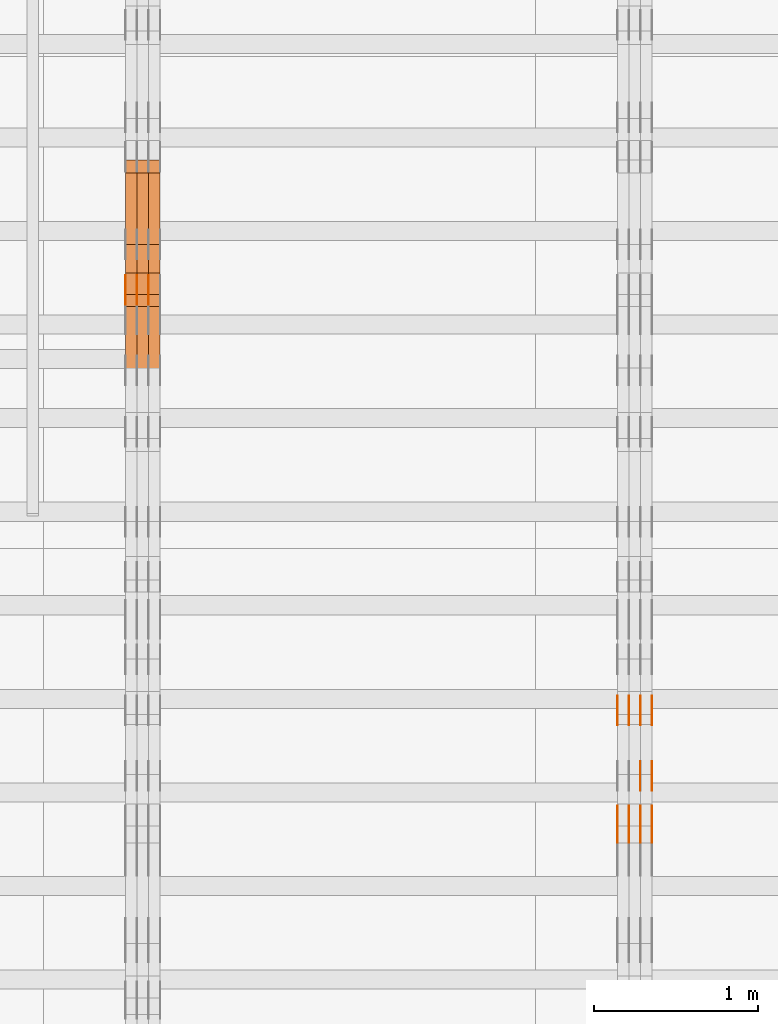
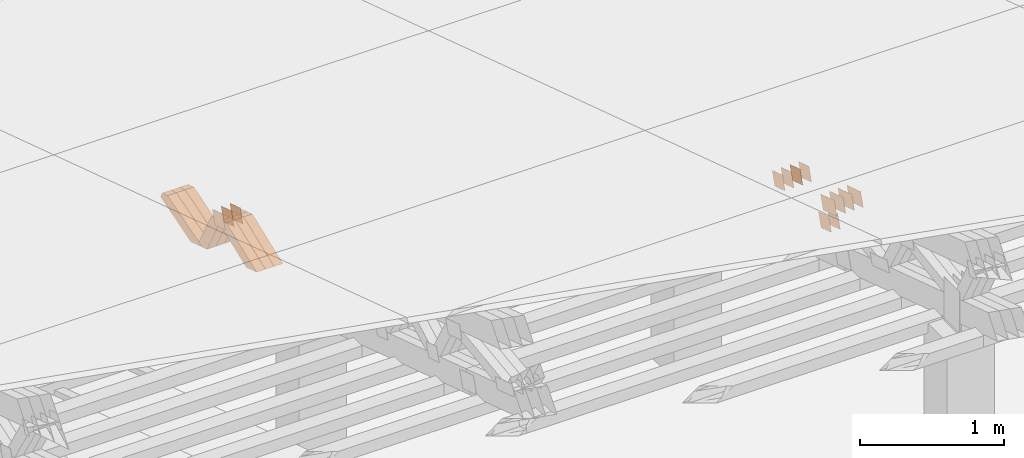
# One storey, part 193 of 385: 28 proxies.
"""IFC2X3 building model written with IfcOpenShell, lengths in millimetres."""

from ifc_helpers import new_model, entity, si_unit, converted_unit, derived_unit, direction, frame, origin, place, context, subcontext, project, spatial, polyline, outline, extrude, source, transform, mapped, material, type_object, type_shapes, element, save


model = new_model("IFC2X3")

# Units and contexts
model_context = context("Model", 3, precision=0.01, world=origin(), true_north=direction((6.12303176911189e-17, 1.0)))
body_context = subcontext(model_context, "Body", "Model", "MODEL_VIEW")
ifc_project = project(units=[si_unit("LENGTHUNIT", "METRE", prefix="MILLI"), si_unit("AREAUNIT", "SQUARE_METRE"), si_unit("VOLUMEUNIT", "CUBIC_METRE"), converted_unit("PLANEANGLEUNIT", "DEGREE", entity("IfcRatioMeasure", 0.0174532925199433), si_unit("PLANEANGLEUNIT", "RADIAN"), dimensions=[0, 0, 0, 0, 0, 0, 0]), si_unit("MASSUNIT", "GRAM", prefix="KILO"), derived_unit("MASSDENSITYUNIT", [(si_unit("MASSUNIT", "GRAM", prefix="KILO"), 1), (si_unit("LENGTHUNIT", "METRE"), -3)]), si_unit("TIMEUNIT", "SECOND"), si_unit("FREQUENCYUNIT", "HERTZ"), si_unit("THERMODYNAMICTEMPERATUREUNIT", "DEGREE_CELSIUS"), derived_unit("THERMALTRANSMITTANCEUNIT", [(si_unit("MASSUNIT", "GRAM", prefix="KILO"), 1), (si_unit("THERMODYNAMICTEMPERATUREUNIT", "KELVIN"), -1), (si_unit("TIMEUNIT", "SECOND"), -3)]), derived_unit("VOLUMETRICFLOWRATEUNIT", [(si_unit("LENGTHUNIT", "METRE"), 3), (si_unit("TIMEUNIT", "SECOND"), -1)]), si_unit("ELECTRICCURRENTUNIT", "AMPERE"), si_unit("ELECTRICVOLTAGEUNIT", "VOLT"), si_unit("POWERUNIT", "WATT"), si_unit("FORCEUNIT", "NEWTON", prefix="KILO"), si_unit("ILLUMINANCEUNIT", "LUX"), si_unit("LUMINOUSFLUXUNIT", "LUMEN"), si_unit("LUMINOUSINTENSITYUNIT", "CANDELA"), derived_unit("USERDEFINED", [(si_unit("MASSUNIT", "GRAM", prefix="KILO"), -1), (si_unit("LENGTHUNIT", "METRE"), -2), (si_unit("TIMEUNIT", "SECOND"), 3), (si_unit("LUMINOUSFLUXUNIT", "LUMEN"), 1)]), derived_unit("LINEARVELOCITYUNIT", [(si_unit("LENGTHUNIT", "METRE"), 1), (si_unit("TIMEUNIT", "SECOND"), -1)]), si_unit("PRESSUREUNIT", "PASCAL"), derived_unit("USERDEFINED", [(si_unit("LENGTHUNIT", "METRE"), -2), (si_unit("MASSUNIT", "GRAM", prefix="KILO"), 1), (si_unit("TIMEUNIT", "SECOND"), -2)])], contexts=[model_context])

# Site, building, storey
site_placement = place(None, origin())
site = spatial("IfcSite", under=ifc_project, at=site_placement, CompositionType="ELEMENT")
building_placement = place(site_placement, origin())
building = spatial("IfcBuilding", under=site, at=building_placement, CompositionType="ELEMENT")
storey_placement = place(building_placement, origin())
storey = spatial("IfcBuildingStorey", under=building, at=storey_placement, Name="Default", CompositionType="ELEMENT", Elevation=0.0)

# Proxies
ifc_material_1 = material(Name="IfcSurfaceStyle #176418")
building_element_proxy_type_1 = type_object("IfcBuildingElementProxyType", PredefinedType="NOTDEFINED", material=ifc_material_1)
shared_shape_1 = source(origin(), body_context, "Body", "SweptSolid", [
    extrude(outline(polyline([(-74.9998982809088, -60.000042563519), (74.9998377068237, -60.000042563519), (74.9998982809079, 60.0000425635189), (-74.9998377068227, 60.0000425635189), (-74.9998982809088, -60.000042563519)])), frame((75.0001050385304, 60.0001177331169, 0.0), z_axis=(0.0, 0.0, 1.0), x_axis=(-1.0, 0.0, 0.0)), (0.0, 0.0, 1.0), 1.3),
])
type_shapes(building_element_proxy_type_1, [shared_shape_1])
proxy_1_placement = place(building_placement, frame((12386.3, 19806.7306653882, 2506.65203571776), z_axis=(-1.0, 0.0, 0.0), x_axis=(0.0, -0.951056516295154, 0.309016994374948)))
element("IfcBuildingElementProxy", 1, at=proxy_1_placement, inside=storey, type_object=building_element_proxy_type_1, material=ifc_material_1, context=body_context, shape_type="MappedRepresentation", body=[
    mapped(shared_shape_1, transform((0.0, 0.0, 0.0), scale=1.0)),
])
ifc_material_2 = material(Name="IfcSurfaceStyle #176361")
building_element_proxy_type_2 = type_object("IfcBuildingElementProxyType", PredefinedType="NOTDEFINED", material=ifc_material_2)
shared_shape_2 = source(origin(), body_context, "Body", "SweptSolid", [
    extrude(outline(polyline([(-74.9998982809088, -60.000042563519), (74.9998377068237, -60.000042563519), (74.9998982809079, 60.0000425635189), (-74.9998377068227, 60.0000425635189), (-74.9998982809088, -60.000042563519)])), frame((75.0001050385304, 60.0001177331169, 0.0), z_axis=(0.0, 0.0, 1.0), x_axis=(-1.0, 0.0, 0.0)), (0.0, 0.0, 1.0), 1.3),
])
type_shapes(building_element_proxy_type_2, [shared_shape_2])
proxy_2_placement = place(building_placement, frame((12315.0, 19806.7306653882, 2506.65203571776), z_axis=(-1.0, 0.0, 0.0), x_axis=(0.0, -0.951056516295154, 0.309016994374948)))
element("IfcBuildingElementProxy", 2, at=proxy_2_placement, inside=storey, type_object=building_element_proxy_type_2, material=ifc_material_2, context=body_context, shape_type="MappedRepresentation", body=[
    mapped(shared_shape_2, transform((0.0, 0.0, 0.0), scale=1.0)),
])
ifc_material_3 = material(Name="IfcSurfaceStyle #176304")
building_element_proxy_type_3 = type_object("IfcBuildingElementProxyType", PredefinedType="NOTDEFINED", material=ifc_material_3)
shared_shape_3 = source(origin(), body_context, "Body", "SweptSolid", [
    extrude(outline(polyline([(-74.9998982809088, -60.000042563519), (74.9998377068237, -60.000042563519), (74.9998982809079, 60.0000425635189), (-74.9998377068227, 60.0000425635189), (-74.9998982809088, -60.000042563519)])), frame((75.0001050385304, 60.0001177331169, 0.0), z_axis=(0.0, 0.0, 1.0), x_axis=(-1.0, 0.0, 0.0)), (0.0, 0.0, 1.0), 1.3),
])
type_shapes(building_element_proxy_type_3, [shared_shape_3])
proxy_3_placement = place(building_placement, frame((12316.3, 19806.7306653882, 2506.65203571776), z_axis=(-1.0, 0.0, 0.0), x_axis=(0.0, -0.951056516295154, 0.309016994374948)))
element("IfcBuildingElementProxy", 3, at=proxy_3_placement, inside=storey, type_object=building_element_proxy_type_3, material=ifc_material_3, context=body_context, shape_type="MappedRepresentation", body=[
    mapped(shared_shape_3, transform((0.0, 0.0, 0.0), scale=1.0)),
])
ifc_material_4 = material(Name="IfcSurfaceStyle #176247")
building_element_proxy_type_4 = type_object("IfcBuildingElementProxyType", PredefinedType="NOTDEFINED", material=ifc_material_4)
shared_shape_4 = source(origin(), body_context, "Body", "SweptSolid", [
    extrude(outline(polyline([(-74.9998982809088, -60.000042563519), (74.9998377068237, -60.000042563519), (74.9998982809079, 60.0000425635189), (-74.9998377068227, 60.0000425635189), (-74.9998982809088, -60.000042563519)])), frame((75.0001050385304, 60.0001177331169, 0.0), z_axis=(0.0, 0.0, 1.0), x_axis=(-1.0, 0.0, 0.0)), (0.0, 0.0, 1.0), 1.29999999999999),
])
type_shapes(building_element_proxy_type_4, [shared_shape_4])
proxy_4_placement = place(building_placement, frame((12245.0, 19806.7306653882, 2506.65203571776), z_axis=(-1.0, 0.0, 0.0), x_axis=(0.0, -0.951056516295154, 0.309016994374948)))
element("IfcBuildingElementProxy", 4, at=proxy_4_placement, inside=storey, type_object=building_element_proxy_type_4, material=ifc_material_4, context=body_context, shape_type="MappedRepresentation", body=[
    mapped(shared_shape_4, transform((0.0, 0.0, 0.0), scale=1.0)),
])
ifc_material_5 = material(Name="IfcSurfaceStyle #176190")
building_element_proxy_type_5 = type_object("IfcBuildingElementProxyType", PredefinedType="NOTDEFINED", material=ifc_material_5)
shared_shape_5 = source(origin(), body_context, "Body", "SweptSolid", [
    extrude(outline(polyline([(-74.9998982809088, -60.000042563519), (74.9998377068237, -60.000042563519), (74.9998982809079, 60.0000425635189), (-74.9998377068227, 60.0000425635189), (-74.9998982809088, -60.000042563519)])), frame((75.0001050385304, 60.0001177331169, 0.0), z_axis=(0.0, 0.0, 1.0), x_axis=(-1.0, 0.0, 0.0)), (0.0, 0.0, 1.0), 1.29999999999999),
])
type_shapes(building_element_proxy_type_5, [shared_shape_5])
proxy_5_placement = place(building_placement, frame((12246.3, 19806.7306653882, 2506.65203571776), z_axis=(-1.0, 0.0, 0.0), x_axis=(0.0, -0.951056516295154, 0.309016994374948)))
element("IfcBuildingElementProxy", 5, at=proxy_5_placement, inside=storey, type_object=building_element_proxy_type_5, material=ifc_material_5, context=body_context, shape_type="MappedRepresentation", body=[
    mapped(shared_shape_5, transform((0.0, 0.0, 0.0), scale=1.0)),
])
ifc_material_6 = material(Name="IfcSurfaceStyle #176133")
building_element_proxy_type_6 = type_object("IfcBuildingElementProxyType", PredefinedType="NOTDEFINED", material=ifc_material_6)
shared_shape_6 = source(origin(), body_context, "Body", "SweptSolid", [
    extrude(outline(polyline([(-74.9998982809088, -60.000042563519), (74.9998377068237, -60.000042563519), (74.9998982809079, 60.0000425635189), (-74.9998377068227, 60.0000425635189), (-74.9998982809088, -60.000042563519)])), frame((75.0001050385304, 60.0001177331169, 0.0), z_axis=(0.0, 0.0, 1.0), x_axis=(-1.0, 0.0, 0.0)), (0.0, 0.0, 1.0), 1.29999999999999),
])
type_shapes(building_element_proxy_type_6, [shared_shape_6])
proxy_6_placement = place(building_placement, frame((12175.0, 19806.7306653882, 2506.65203571776), z_axis=(-1.0, 0.0, 0.0), x_axis=(0.0, -0.951056516295154, 0.309016994374948)))
element("IfcBuildingElementProxy", 6, at=proxy_6_placement, inside=storey, type_object=building_element_proxy_type_6, material=ifc_material_6, context=body_context, shape_type="MappedRepresentation", body=[
    mapped(shared_shape_6, transform((0.0, 0.0, 0.0), scale=1.0)),
])
ifc_material_7 = material(Name="IfcSurfaceStyle #175050")
building_element_proxy_type_7 = type_object("IfcBuildingElementProxyType", PredefinedType="NOTDEFINED", material=ifc_material_7)
shared_shape_7 = source(origin(), body_context, "Body", "SweptSolid", [
    extrude(outline(polyline([(-99.9998479918963, -59.9999913366637), (99.9998251396114, -59.9999913366637), (99.9998102700952, 59.9999913366637), (-99.9997874178102, 59.9999913366637), (-99.9998479918963, -59.9999913366637)])), frame((99.9998251396114, 60.0000609537942, 0.0), z_axis=(0.0, 0.0, 1.0), x_axis=(-1.0, 0.0, 0.0)), (0.0, 0.0, 1.0), 1.3),
])
type_shapes(building_element_proxy_type_7, [shared_shape_7])
proxy_7_placement = place(building_placement, frame((12386.3, 19136.9072023289, 2711.67346128215), z_axis=(-1.0, 0.0, 0.0), x_axis=(0.0, -0.951056516295154, 0.309016994374948)))
element("IfcBuildingElementProxy", 7, at=proxy_7_placement, inside=storey, type_object=building_element_proxy_type_7, material=ifc_material_7, context=body_context, shape_type="MappedRepresentation", body=[
    mapped(shared_shape_7, transform((0.0, 0.0, 0.0), scale=1.0)),
])
ifc_material_8 = material(Name="IfcSurfaceStyle #174993")
building_element_proxy_type_8 = type_object("IfcBuildingElementProxyType", PredefinedType="NOTDEFINED", material=ifc_material_8)
shared_shape_8 = source(origin(), body_context, "Body", "SweptSolid", [
    extrude(outline(polyline([(-99.9998479918963, -59.9999913366637), (99.9998251396114, -59.9999913366637), (99.9998102700952, 59.9999913366637), (-99.9997874178102, 59.9999913366637), (-99.9998479918963, -59.9999913366637)])), frame((99.9998251396114, 60.0000609537942, 0.0), z_axis=(0.0, 0.0, 1.0), x_axis=(-1.0, 0.0, 0.0)), (0.0, 0.0, 1.0), 1.3),
])
type_shapes(building_element_proxy_type_8, [shared_shape_8])
proxy_8_placement = place(building_placement, frame((12315.0, 19136.9072023289, 2711.67346128215), z_axis=(-1.0, 0.0, 0.0), x_axis=(0.0, -0.951056516295154, 0.309016994374948)))
element("IfcBuildingElementProxy", 8, at=proxy_8_placement, inside=storey, type_object=building_element_proxy_type_8, material=ifc_material_8, context=body_context, shape_type="MappedRepresentation", body=[
    mapped(shared_shape_8, transform((0.0, 0.0, 0.0), scale=1.0)),
])
ifc_material_9 = material(Name="IfcSurfaceStyle #174936")
building_element_proxy_type_9 = type_object("IfcBuildingElementProxyType", PredefinedType="NOTDEFINED", material=ifc_material_9)
shared_shape_9 = source(origin(), body_context, "Body", "SweptSolid", [
    extrude(outline(polyline([(-99.9998479918963, -59.9999913366637), (99.9998251396114, -59.9999913366637), (99.9998102700952, 59.9999913366637), (-99.9997874178102, 59.9999913366637), (-99.9998479918963, -59.9999913366637)])), frame((99.9998251396114, 60.0000609537942, 0.0), z_axis=(0.0, 0.0, 1.0), x_axis=(-1.0, 0.0, 0.0)), (0.0, 0.0, 1.0), 1.3),
])
type_shapes(building_element_proxy_type_9, [shared_shape_9])
proxy_9_placement = place(building_placement, frame((12316.3, 19136.9072023289, 2711.67346128215), z_axis=(-1.0, 0.0, 0.0), x_axis=(0.0, -0.951056516295154, 0.309016994374948)))
element("IfcBuildingElementProxy", 9, at=proxy_9_placement, inside=storey, type_object=building_element_proxy_type_9, material=ifc_material_9, context=body_context, shape_type="MappedRepresentation", body=[
    mapped(shared_shape_9, transform((0.0, 0.0, 0.0), scale=1.0)),
])
ifc_material_10 = material(Name="IfcSurfaceStyle #174879")
building_element_proxy_type_10 = type_object("IfcBuildingElementProxyType", PredefinedType="NOTDEFINED", material=ifc_material_10)
shared_shape_10 = source(origin(), body_context, "Body", "SweptSolid", [
    extrude(outline(polyline([(-99.9998479918963, -59.9999913366637), (99.9998251396114, -59.9999913366637), (99.9998102700952, 59.9999913366637), (-99.9997874178102, 59.9999913366637), (-99.9998479918963, -59.9999913366637)])), frame((99.9998251396114, 60.0000609537942, 0.0), z_axis=(0.0, 0.0, 1.0), x_axis=(-1.0, 0.0, 0.0)), (0.0, 0.0, 1.0), 1.29999999999998),
])
type_shapes(building_element_proxy_type_10, [shared_shape_10])
proxy_10_placement = place(building_placement, frame((12245.0, 19136.9072023289, 2711.67346128215), z_axis=(-1.0, 0.0, 0.0), x_axis=(0.0, -0.951056516295154, 0.309016994374948)))
element("IfcBuildingElementProxy", 10, at=proxy_10_placement, inside=storey, type_object=building_element_proxy_type_10, material=ifc_material_10, context=body_context, shape_type="MappedRepresentation", body=[
    mapped(shared_shape_10, transform((0.0, 0.0, 0.0), scale=1.0)),
])
ifc_material_11 = material(Name="IfcSurfaceStyle #174822")
building_element_proxy_type_11 = type_object("IfcBuildingElementProxyType", PredefinedType="NOTDEFINED", material=ifc_material_11)
shared_shape_11 = source(origin(), body_context, "Body", "SweptSolid", [
    extrude(outline(polyline([(-99.9998479918963, -59.9999913366637), (99.9998251396114, -59.9999913366637), (99.9998102700952, 59.9999913366637), (-99.9997874178102, 59.9999913366637), (-99.9998479918963, -59.9999913366637)])), frame((99.9998251396114, 60.0000609537942, 0.0), z_axis=(0.0, 0.0, 1.0), x_axis=(-1.0, 0.0, 0.0)), (0.0, 0.0, 1.0), 1.29999999999998),
])
type_shapes(building_element_proxy_type_11, [shared_shape_11])
proxy_11_placement = place(building_placement, frame((12246.3, 19136.9072023289, 2711.67346128215), z_axis=(-1.0, 0.0, 0.0), x_axis=(0.0, -0.951056516295154, 0.309016994374948)))
element("IfcBuildingElementProxy", 11, at=proxy_11_placement, inside=storey, type_object=building_element_proxy_type_11, material=ifc_material_11, context=body_context, shape_type="MappedRepresentation", body=[
    mapped(shared_shape_11, transform((0.0, 0.0, 0.0), scale=1.0)),
])
ifc_material_12 = material(Name="IfcSurfaceStyle #174765")
building_element_proxy_type_12 = type_object("IfcBuildingElementProxyType", PredefinedType="NOTDEFINED", material=ifc_material_12)
shared_shape_12 = source(origin(), body_context, "Body", "SweptSolid", [
    extrude(outline(polyline([(-99.9998479918963, -59.9999913366637), (99.9998251396114, -59.9999913366637), (99.9998102700952, 59.9999913366637), (-99.9997874178102, 59.9999913366637), (-99.9998479918963, -59.9999913366637)])), frame((99.9998251396114, 60.0000609537942, 0.0), z_axis=(0.0, 0.0, 1.0), x_axis=(-1.0, 0.0, 0.0)), (0.0, 0.0, 1.0), 1.29999999999999),
])
type_shapes(building_element_proxy_type_12, [shared_shape_12])
proxy_12_placement = place(building_placement, frame((12175.0, 19136.9072023289, 2711.67346128215), z_axis=(-1.0, 0.0, 0.0), x_axis=(0.0, -0.951056516295154, 0.309016994374948)))
element("IfcBuildingElementProxy", 12, at=proxy_12_placement, inside=storey, type_object=building_element_proxy_type_12, material=ifc_material_12, context=body_context, shape_type="MappedRepresentation", body=[
    mapped(shared_shape_12, transform((0.0, 0.0, 0.0), scale=1.0)),
])
ifc_material_13 = material(Name="IfcSurfaceStyle #169920")
building_element_proxy_type_13 = type_object("IfcBuildingElementProxyType", PredefinedType="NOTDEFINED", material=ifc_material_13)
shared_shape_13 = source(origin(), body_context, "Body", "SweptSolid", [
    extrude(outline(polyline([(-74.9998605591127, -59.9999264677599), (74.999875428618, -59.9999264677599), (74.9998605591127, 59.9999264677599), (-74.999875428618, 59.9999264677599), (-74.9998605591127, -59.9999264677599)])), frame((75.0002655673825, 60.0000016373433, 0.0), z_axis=(0.0, 0.0, 1.0), x_axis=(-1.0, 0.0, 0.0)), (0.0, 0.0, 1.0), 1.3),
])
type_shapes(building_element_proxy_type_13, [shared_shape_13])
proxy_13_placement = place(building_placement, frame((12386.3, 19407.1136664358, 2348.71056820494), z_axis=(-1.0, 0.0, 0.0), x_axis=(0.0, -0.951056516295124, 0.309016994375039)))
element("IfcBuildingElementProxy", 13, at=proxy_13_placement, inside=storey, type_object=building_element_proxy_type_13, material=ifc_material_13, context=body_context, shape_type="MappedRepresentation", body=[
    mapped(shared_shape_13, transform((0.0, 0.0, 0.0), scale=1.0)),
])
ifc_material_14 = material(Name="IfcSurfaceStyle #169863")
building_element_proxy_type_14 = type_object("IfcBuildingElementProxyType", PredefinedType="NOTDEFINED", material=ifc_material_14)
shared_shape_14 = source(origin(), body_context, "Body", "SweptSolid", [
    extrude(outline(polyline([(-74.9998605591127, -59.9999264677599), (74.999875428618, -59.9999264677599), (74.9998605591127, 59.9999264677599), (-74.999875428618, 59.9999264677599), (-74.9998605591127, -59.9999264677599)])), frame((75.0002655673825, 60.0000016373433, 0.0), z_axis=(0.0, 0.0, 1.0), x_axis=(-1.0, 0.0, 0.0)), (0.0, 0.0, 1.0), 1.3),
])
type_shapes(building_element_proxy_type_14, [shared_shape_14])
proxy_14_placement = place(building_placement, frame((12315.0, 19407.1136664358, 2348.71056820494), z_axis=(-1.0, 0.0, 0.0), x_axis=(0.0, -0.951056516295124, 0.309016994375039)))
element("IfcBuildingElementProxy", 14, at=proxy_14_placement, inside=storey, type_object=building_element_proxy_type_14, material=ifc_material_14, context=body_context, shape_type="MappedRepresentation", body=[
    mapped(shared_shape_14, transform((0.0, 0.0, 0.0), scale=1.0)),
])
ifc_material_15 = material(Name="IfcSurfaceStyle #128249")
building_element_proxy_type_15 = type_object("IfcBuildingElementProxyType", PredefinedType="NOTDEFINED", material=ifc_material_15)
shared_shape_15 = source(origin(), body_context, "Body", "SweptSolid", [
    extrude(outline(polyline([(-74.9998794200069, -59.9999845156358), (74.9998565677229, -59.9999845156358), (74.9998794200069, 59.9999845156358), (-74.9998565677229, 59.9999845156358), (-74.9998794200069, -59.9999845156358)])), frame((75.0000966453795, 60.0000596852335, 0.0), z_axis=(0.0, 0.0, 1.0), x_axis=(-1.0, 0.0, 0.0)), (0.0, 0.0, 1.0), 1.3),
])
type_shapes(building_element_proxy_type_15, [shared_shape_15])
proxy_15_placement = place(building_placement, frame((9315.0, 22372.1881948749, 1673.08440552992), z_axis=(-1.0, 0.0, 0.0), x_axis=(0.0, -0.951056516295154, 0.309016994374948)))
element("IfcBuildingElementProxy", 15, at=proxy_15_placement, inside=storey, type_object=building_element_proxy_type_15, material=ifc_material_15, context=body_context, shape_type="MappedRepresentation", body=[
    mapped(shared_shape_15, transform((0.0, 0.0, 0.0), scale=1.0)),
])
ifc_material_16 = material(Name="IfcSurfaceStyle #128192")
building_element_proxy_type_16 = type_object("IfcBuildingElementProxyType", PredefinedType="NOTDEFINED", material=ifc_material_16)
shared_shape_16 = source(origin(), body_context, "Body", "SweptSolid", [
    extrude(outline(polyline([(-74.9998794200069, -59.9999845156358), (74.9998565677229, -59.9999845156358), (74.9998794200069, 59.9999845156358), (-74.9998565677229, 59.9999845156358), (-74.9998794200069, -59.9999845156358)])), frame((75.0000966453795, 60.0000596852335, 0.0), z_axis=(0.0, 0.0, 1.0), x_axis=(-1.0, 0.0, 0.0)), (0.0, 0.0, 1.0), 1.3),
])
type_shapes(building_element_proxy_type_16, [shared_shape_16])
proxy_16_placement = place(building_placement, frame((9316.29999999998, 22372.1881948749, 1673.08440552992), z_axis=(-1.0, 0.0, 0.0), x_axis=(0.0, -0.951056516295154, 0.309016994374948)))
element("IfcBuildingElementProxy", 16, at=proxy_16_placement, inside=storey, type_object=building_element_proxy_type_16, material=ifc_material_16, context=body_context, shape_type="MappedRepresentation", body=[
    mapped(shared_shape_16, transform((0.0, 0.0, 0.0), scale=1.0)),
])
ifc_material_17 = material(Name="IfcSurfaceStyle #128135")
building_element_proxy_type_17 = type_object("IfcBuildingElementProxyType", PredefinedType="NOTDEFINED", material=ifc_material_17)
shared_shape_17 = source(origin(), body_context, "Body", "SweptSolid", [
    extrude(outline(polyline([(-74.9998794200069, -59.9999845156358), (74.9998565677229, -59.9999845156358), (74.9998794200069, 59.9999845156358), (-74.9998565677229, 59.9999845156358), (-74.9998794200069, -59.9999845156358)])), frame((75.0000966453795, 60.0000596852335, 0.0), z_axis=(0.0, 0.0, 1.0), x_axis=(-1.0, 0.0, 0.0)), (0.0, 0.0, 1.0), 1.29999999999999),
])
type_shapes(building_element_proxy_type_17, [shared_shape_17])
proxy_17_placement = place(building_placement, frame((9245.0, 22372.1881948749, 1673.08440552992), z_axis=(-1.0, 0.0, 0.0), x_axis=(0.0, -0.951056516295154, 0.309016994374948)))
element("IfcBuildingElementProxy", 17, at=proxy_17_placement, inside=storey, type_object=building_element_proxy_type_17, material=ifc_material_17, context=body_context, shape_type="MappedRepresentation", body=[
    mapped(shared_shape_17, transform((0.0, 0.0, 0.0), scale=1.0)),
])
ifc_material_18 = material(Name="IfcSurfaceStyle #128078")
building_element_proxy_type_18 = type_object("IfcBuildingElementProxyType", PredefinedType="NOTDEFINED", material=ifc_material_18)
shared_shape_18 = source(origin(), body_context, "Body", "SweptSolid", [
    extrude(outline(polyline([(-74.9998794200069, -59.9999845156358), (74.9998565677229, -59.9999845156358), (74.9998794200069, 59.9999845156358), (-74.9998565677229, 59.9999845156358), (-74.9998794200069, -59.9999845156358)])), frame((75.0000966453795, 60.0000596852335, 0.0), z_axis=(0.0, 0.0, 1.0), x_axis=(-1.0, 0.0, 0.0)), (0.0, 0.0, 1.0), 1.29999999999999),
])
type_shapes(building_element_proxy_type_18, [shared_shape_18])
proxy_18_placement = place(building_placement, frame((9246.29999999998, 22372.1881948749, 1673.08440552992), z_axis=(-1.0, 0.0, 0.0), x_axis=(0.0, -0.951056516295154, 0.309016994374948)))
element("IfcBuildingElementProxy", 18, at=proxy_18_placement, inside=storey, type_object=building_element_proxy_type_18, material=ifc_material_18, context=body_context, shape_type="MappedRepresentation", body=[
    mapped(shared_shape_18, transform((0.0, 0.0, 0.0), scale=1.0)),
])
ifc_material_19 = material(Name="IfcSurfaceStyle #128021")
building_element_proxy_type_19 = type_object("IfcBuildingElementProxyType", PredefinedType="NOTDEFINED", material=ifc_material_19)
shared_shape_19 = source(origin(), body_context, "Body", "SweptSolid", [
    extrude(outline(polyline([(-74.9998794200069, -59.9999845156358), (74.9998565677229, -59.9999845156358), (74.9998794200069, 59.9999845156358), (-74.9998565677229, 59.9999845156358), (-74.9998794200069, -59.9999845156358)])), frame((75.0000966453795, 60.0000596852335, 0.0), z_axis=(0.0, 0.0, 1.0), x_axis=(-1.0, 0.0, 0.0)), (0.0, 0.0, 1.0), 1.29999999999999),
])
type_shapes(building_element_proxy_type_19, [shared_shape_19])
proxy_19_placement = place(building_placement, frame((9175.0, 22372.1881948749, 1673.08440552992), z_axis=(-1.0, 0.0, 0.0), x_axis=(0.0, -0.951056516295154, 0.309016994374948)))
element("IfcBuildingElementProxy", 19, at=proxy_19_placement, inside=storey, type_object=building_element_proxy_type_19, material=ifc_material_19, context=body_context, shape_type="MappedRepresentation", body=[
    mapped(shared_shape_19, transform((0.0, 0.0, 0.0), scale=1.0)),
])
ifc_material_20 = material(Name="IfcSurfaceStyle #115958")
building_element_proxy_type_20 = type_object("IfcBuildingElementProxyType", Name="T1-W30 115956", PredefinedType="NOTDEFINED", material=ifc_material_20)
shared_shape_20 = source(origin(), body_context, "Body", "SweptSolid", [
    extrude(outline(polyline([(-319.322304176575, -47.5000259045904), (133.154090927094, -47.5000259045904), (191.489196707701, 6.99403755251016e-06), (197.330697834052, 47.5000224075717), (-202.651681292271, 47.5000224075717), (-319.322304176575, -47.5000259045904)])), frame((197.330834478517, 47.5000608592405, 0.0), z_axis=(0.0, 0.0, 1.0), x_axis=(-1.0, 0.0, 0.0)), (0.0, 0.0, 1.0), 70.0),
])
type_shapes(building_element_proxy_type_20, [shared_shape_20])
proxy_20_placement = place(building_placement, frame((9385.0, 22312.5352975627, 1720.70362673362), z_axis=(-1.0, 0.0, 0.0), x_axis=(0.0, -0.932610696879359, -0.360884036868072)))
element("IfcBuildingElementProxy", 20, at=proxy_20_placement, inside=storey, type_object=building_element_proxy_type_20, material=ifc_material_20, Name="T1-W30", context=body_context, shape_type="MappedRepresentation", body=[
    mapped(shared_shape_20, transform((0.0, 0.0, 0.0), scale=1.0)),
])
ifc_material_21 = material(Name="IfcSurfaceStyle #115892")
building_element_proxy_type_21 = type_object("IfcBuildingElementProxyType", Name="T1-W30 115890", PredefinedType="NOTDEFINED", material=ifc_material_21)
shared_shape_21 = source(origin(), body_context, "Body", "SweptSolid", [
    extrude(outline(polyline([(-319.322304176575, -47.5000259045904), (133.154090927094, -47.5000259045904), (191.489196707701, 6.99403755251016e-06), (197.330697834052, 47.5000224075717), (-202.651681292271, 47.5000224075717), (-319.322304176575, -47.5000259045904)])), frame((197.330834478517, 47.5000608592405, 0.0), z_axis=(0.0, 0.0, 1.0), x_axis=(-1.0, 0.0, 0.0)), (0.0, 0.0, 1.0), 70.0),
])
type_shapes(building_element_proxy_type_21, [shared_shape_21])
proxy_21_placement = place(building_placement, frame((9315.0, 22312.5352975627, 1720.70362673362), z_axis=(-1.0, 0.0, 0.0), x_axis=(0.0, -0.932610696879359, -0.360884036868072)))
element("IfcBuildingElementProxy", 21, at=proxy_21_placement, inside=storey, type_object=building_element_proxy_type_21, material=ifc_material_21, Name="T1-W30", context=body_context, shape_type="MappedRepresentation", body=[
    mapped(shared_shape_21, transform((0.0, 0.0, 0.0), scale=1.0)),
])
ifc_material_22 = material(Name="IfcSurfaceStyle #115826")
building_element_proxy_type_22 = type_object("IfcBuildingElementProxyType", Name="T1-W30 115824", PredefinedType="NOTDEFINED", material=ifc_material_22)
shared_shape_22 = source(origin(), body_context, "Body", "SweptSolid", [
    extrude(outline(polyline([(-319.322304176575, -47.5000259045904), (133.154090927094, -47.5000259045904), (191.489196707701, 6.99403755251016e-06), (197.330697834052, 47.5000224075717), (-202.651681292271, 47.5000224075717), (-319.322304176575, -47.5000259045904)])), frame((197.330834478517, 47.5000608592405, 0.0), z_axis=(0.0, 0.0, 1.0), x_axis=(-1.0, 0.0, 0.0)), (0.0, 0.0, 1.0), 70.0),
])
type_shapes(building_element_proxy_type_22, [shared_shape_22])
proxy_22_placement = place(building_placement, frame((9245.0, 22312.5352975627, 1720.70362673362), z_axis=(-1.0, 0.0, 0.0), x_axis=(0.0, -0.932610696879359, -0.360884036868072)))
element("IfcBuildingElementProxy", 22, at=proxy_22_placement, inside=storey, type_object=building_element_proxy_type_22, material=ifc_material_22, Name="T1-W30", context=body_context, shape_type="MappedRepresentation", body=[
    mapped(shared_shape_22, transform((0.0, 0.0, 0.0), scale=1.0)),
])
ifc_material_23 = material(Name="IfcSurfaceStyle #115562")
building_element_proxy_type_23 = type_object("IfcBuildingElementProxyType", Name="T1-W41 115560", PredefinedType="NOTDEFINED", material=ifc_material_23)
shared_shape_23 = source(origin(), body_context, "Body", "SweptSolid", [
    extrude(outline(polyline([(-190.064783497519, -47.5001011048749), (182.590736871656, -47.5001011048749), (172.978793750747, 0.000111395300689243), (123.505951450908, 47.5000454072246), (-289.010698575792, 47.5000454072246), (-190.064783497519, -47.5001011048749)])), frame((182.590736871656, 47.5001973817447, 0.0), z_axis=(0.0, 0.0, 1.0), x_axis=(-1.0, 0.0, 0.0)), (0.0, 0.0, 1.0), 70.0),
])
type_shapes(building_element_proxy_type_23, [shared_shape_23])
proxy_23_placement = place(building_placement, frame((9385.0, 22512.5506969064, 1347.13648051689), z_axis=(-1.0, 0.0, 0.0), x_axis=(0.0, -0.472020158706979, 0.881587755004706)))
element("IfcBuildingElementProxy", 23, at=proxy_23_placement, inside=storey, type_object=building_element_proxy_type_23, material=ifc_material_23, Name="T1-W41", context=body_context, shape_type="MappedRepresentation", body=[
    mapped(shared_shape_23, transform((0.0, 0.0, 0.0), scale=1.0)),
])
ifc_material_24 = material(Name="IfcSurfaceStyle #115496")
building_element_proxy_type_24 = type_object("IfcBuildingElementProxyType", Name="T1-W41 115494", PredefinedType="NOTDEFINED", material=ifc_material_24)
shared_shape_24 = source(origin(), body_context, "Body", "SweptSolid", [
    extrude(outline(polyline([(-190.064783497519, -47.5001011048749), (182.590736871656, -47.5001011048749), (172.978793750747, 0.000111395300689243), (123.505951450908, 47.5000454072246), (-289.010698575792, 47.5000454072246), (-190.064783497519, -47.5001011048749)])), frame((182.590736871656, 47.5001973817447, 0.0), z_axis=(0.0, 0.0, 1.0), x_axis=(-1.0, 0.0, 0.0)), (0.0, 0.0, 1.0), 70.0),
])
type_shapes(building_element_proxy_type_24, [shared_shape_24])
proxy_24_placement = place(building_placement, frame((9315.0, 22512.5506969064, 1347.13648051689), z_axis=(-1.0, 0.0, 0.0), x_axis=(0.0, -0.472020158706979, 0.881587755004706)))
element("IfcBuildingElementProxy", 24, at=proxy_24_placement, inside=storey, type_object=building_element_proxy_type_24, material=ifc_material_24, Name="T1-W41", context=body_context, shape_type="MappedRepresentation", body=[
    mapped(shared_shape_24, transform((0.0, 0.0, 0.0), scale=1.0)),
])
ifc_material_25 = material(Name="IfcSurfaceStyle #115430")
building_element_proxy_type_25 = type_object("IfcBuildingElementProxyType", Name="T1-W41 115428", PredefinedType="NOTDEFINED", material=ifc_material_25)
shared_shape_25 = source(origin(), body_context, "Body", "SweptSolid", [
    extrude(outline(polyline([(-190.064783497519, -47.5001011048749), (182.590736871656, -47.5001011048749), (172.978793750747, 0.000111395300689243), (123.505951450908, 47.5000454072246), (-289.010698575792, 47.5000454072246), (-190.064783497519, -47.5001011048749)])), frame((182.590736871656, 47.5001973817447, 0.0), z_axis=(0.0, 0.0, 1.0), x_axis=(-1.0, 0.0, 0.0)), (0.0, 0.0, 1.0), 70.0),
])
type_shapes(building_element_proxy_type_25, [shared_shape_25])
proxy_25_placement = place(building_placement, frame((9245.0, 22512.5506969064, 1347.13648051689), z_axis=(-1.0, 0.0, 0.0), x_axis=(0.0, -0.472020158706979, 0.881587755004706)))
element("IfcBuildingElementProxy", 25, at=proxy_25_placement, inside=storey, type_object=building_element_proxy_type_25, material=ifc_material_25, Name="T1-W41", context=body_context, shape_type="MappedRepresentation", body=[
    mapped(shared_shape_25, transform((0.0, 0.0, 0.0), scale=1.0)),
])
ifc_material_26 = material(Name="IfcSurfaceStyle #115166")
building_element_proxy_type_26 = type_object("IfcBuildingElementProxyType", Name="T1-W23 115164", PredefinedType="NOTDEFINED", material=ifc_material_26)
shared_shape_26 = source(origin(), body_context, "Body", "SweptSolid", [
    extrude(outline(polyline([(-356.808656505462, -47.5000180192671), (144.726334557508, -47.5000180192671), (213.258834104997, -2.90494310381195e-05), (218.567145253444, 47.5000325439826), (-219.743657410487, 47.5000325439827), (-356.808656505462, -47.5000180192671)])), frame((218.567145253444, 47.5000325439826, 0.0), z_axis=(0.0, 0.0, 1.0), x_axis=(-1.0, 0.0, 0.0)), (0.0, 0.0, 1.0), 70.0),
])
type_shapes(building_element_proxy_type_26, [shared_shape_26])
proxy_26_placement = place(building_placement, frame((9385.0, 23128.2626953125, 1452.63940429688), z_axis=(-1.0, 0.0, 0.0), x_axis=(0.0, -0.957692700226705, -0.287792793399143)))
element("IfcBuildingElementProxy", 26, at=proxy_26_placement, inside=storey, type_object=building_element_proxy_type_26, material=ifc_material_26, Name="T1-W23", context=body_context, shape_type="MappedRepresentation", body=[
    mapped(shared_shape_26, transform((0.0, 0.0, 0.0), scale=1.0)),
])
ifc_material_27 = material(Name="IfcSurfaceStyle #115100")
building_element_proxy_type_27 = type_object("IfcBuildingElementProxyType", Name="T1-W23 115098", PredefinedType="NOTDEFINED", material=ifc_material_27)
shared_shape_27 = source(origin(), body_context, "Body", "SweptSolid", [
    extrude(outline(polyline([(-356.808656505462, -47.5000180192671), (144.726334557508, -47.5000180192671), (213.258834104997, -2.90494310381195e-05), (218.567145253444, 47.5000325439826), (-219.743657410487, 47.5000325439827), (-356.808656505462, -47.5000180192671)])), frame((218.567145253444, 47.5000325439826, 0.0), z_axis=(0.0, 0.0, 1.0), x_axis=(-1.0, 0.0, 0.0)), (0.0, 0.0, 1.0), 70.0),
])
type_shapes(building_element_proxy_type_27, [shared_shape_27])
proxy_27_placement = place(building_placement, frame((9315.0, 23128.2626953125, 1452.63940429688), z_axis=(-1.0, 0.0, 0.0), x_axis=(0.0, -0.957692700226705, -0.287792793399143)))
element("IfcBuildingElementProxy", 27, at=proxy_27_placement, inside=storey, type_object=building_element_proxy_type_27, material=ifc_material_27, Name="T1-W23", context=body_context, shape_type="MappedRepresentation", body=[
    mapped(shared_shape_27, transform((0.0, 0.0, 0.0), scale=1.0)),
])
ifc_material_28 = material(Name="IfcSurfaceStyle #115034")
building_element_proxy_type_28 = type_object("IfcBuildingElementProxyType", Name="T1-W23 115032", PredefinedType="NOTDEFINED", material=ifc_material_28)
shared_shape_28 = source(origin(), body_context, "Body", "SweptSolid", [
    extrude(outline(polyline([(-356.808656505462, -47.5000180192671), (144.726334557508, -47.5000180192671), (213.258834104997, -2.90494310381195e-05), (218.567145253444, 47.5000325439826), (-219.743657410487, 47.5000325439827), (-356.808656505462, -47.5000180192671)])), frame((218.567145253444, 47.5000325439826, 0.0), z_axis=(0.0, 0.0, 1.0), x_axis=(-1.0, 0.0, 0.0)), (0.0, 0.0, 1.0), 70.0),
])
type_shapes(building_element_proxy_type_28, [shared_shape_28])
proxy_28_placement = place(building_placement, frame((9245.0, 23128.2626953125, 1452.63940429688), z_axis=(-1.0, 0.0, 0.0), x_axis=(0.0, -0.957692700226705, -0.287792793399143)))
element("IfcBuildingElementProxy", 28, at=proxy_28_placement, inside=storey, type_object=building_element_proxy_type_28, material=ifc_material_28, Name="T1-W23", context=body_context, shape_type="MappedRepresentation", body=[
    mapped(shared_shape_28, transform((0.0, 0.0, 0.0), scale=1.0)),
])

save(model, "model.ifc")
